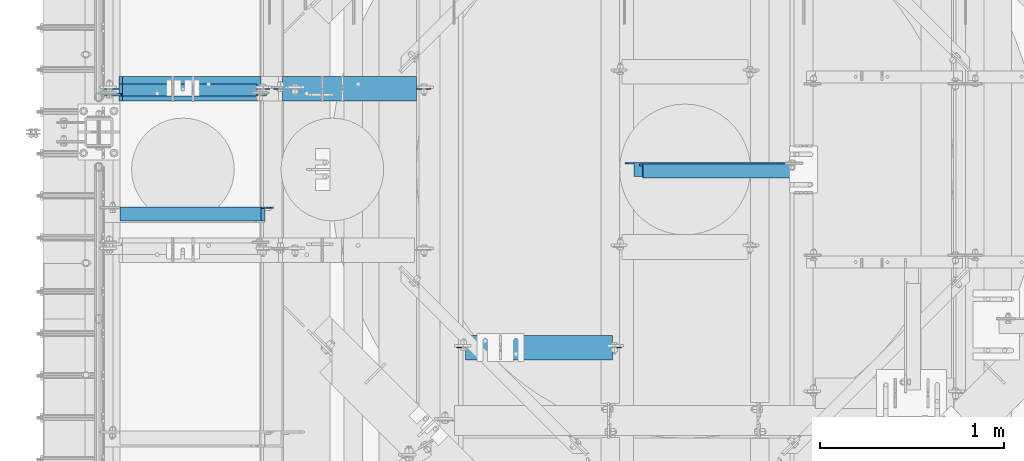
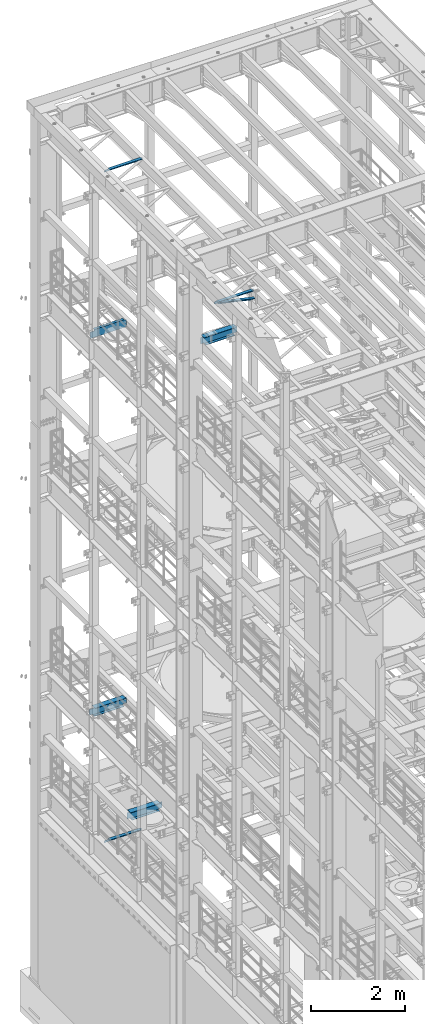
# One storey, part 1310 of 1876: 8 beams, 8 elements without a shape of their own.
"""IFC2X3 building model written with IfcOpenShell, lengths in millimetres."""

from ifc_helpers import new_model, si_unit, frame, origin_with_axes, place, context, subcontext, project, spatial, faceted_brep, material, type_object, element, aggregate, save


model = new_model("IFC2X3")

# Units and contexts
model_context = context("Model", 3, precision=1e-05, world=origin_with_axes())
body_context = subcontext(model_context, "Body", "Model", "MODEL_VIEW")
ifc_project = project(units=[si_unit("LENGTHUNIT", "METRE", prefix="MILLI"), si_unit("AREAUNIT", "SQUARE_METRE"), si_unit("VOLUMEUNIT", "CUBIC_METRE"), si_unit("MASSUNIT", "GRAM", prefix="KILO"), si_unit("TIMEUNIT", "SECOND"), si_unit("PLANEANGLEUNIT", "RADIAN"), si_unit("SOLIDANGLEUNIT", "STERADIAN"), si_unit("THERMODYNAMICTEMPERATUREUNIT", "DEGREE_CELSIUS"), si_unit("LUMINOUSINTENSITYUNIT", "LUMEN")], contexts=[model_context])

# Site, building, storey
site_placement = place(None, origin_with_axes())
site = spatial("IfcSite", under=ifc_project, at=site_placement, CompositionType="ELEMENT")
building_placement = place(site_placement, origin_with_axes())
building = spatial("IfcBuilding", under=site, at=building_placement, Name="Undefined", CompositionType="ELEMENT")
storey_placement = place(building_placement, origin_with_axes())
storey = spatial("IfcBuildingStorey", under=building, at=storey_placement, Name="Undefined", CompositionType="ELEMENT", Elevation=0.0)

# Assembly, beam
assembly_1_placement = place(storey_placement, origin_with_axes())
assembly_1 = element("IfcElementAssembly", 1, at=assembly_1_placement, inside=storey, AssemblyPlace="NOTDEFINED", PredefinedType="RIGID_FRAME")
ifc_material_1 = material(Name="STEEL/A36")
beam_type_1 = type_object("IfcBeamType", Name="L3X3X3/8", PredefinedType="NOTDEFINED")
beam_1_placement = place(assembly_1_placement, frame((2849.26107108996, 11471.2777255477, 17946.0015811523), z_axis=(0.0, -1.0, 0.0), x_axis=(0.976336452709797, -1.1799999937027e-07, -0.216257094935719)))
beam_1 = element("IfcBeam", 2, at=beam_1_placement, type_object=beam_type_1, material=ifc_material_1, ObjectType="L3X3X3/8", context=body_context, shape_type="Brep", body=[
    faceted_brep([(102.771194665975, 38.0999999998821, -38.1000000000022), (102.771194655534, 38.0999999999185, 38.0999999999967), (982.088984028022, 38.0999999990454, 38.0999999997002), (982.088984038462, 38.099999999009, -38.1000000003005), (102.771194655542, 28.5749999999207, 38.0999999999876), (982.08898402803, 28.5749999990512, 38.0999999996911), (102.771194664678, 28.5749999998843, -28.5750000000098), (982.088984037165, 28.5749999990148, -28.5750000003081), (102.771194664737, -38.100000000115, -28.5750000000698), (982.088984037224, -38.1000000009881, -28.5750000003663), (102.771194666042, -38.100000000115, -38.1000000000695), (982.088984038529, -38.1000000009881, -38.100000000366)], [[[0, 1, 2, 3]], [[1, 4, 5, 2]], [[4, 6, 7, 5]], [[6, 8, 9, 7]], [[8, 10, 11, 9]], [[10, 0, 3, 11]], [[5, 7, 9, 11, 3, 2]], [[10, 8, 6, 4, 1, 0]]]),
])
aggregate(assembly_1, [beam_1])

assembly_2_placement = place(storey_placement, origin_with_axes())
assembly_2 = element("IfcElementAssembly", 3, at=assembly_2_placement, inside=storey, Name="ANGLE", AssemblyPlace="NOTDEFINED", PredefinedType="RIGID_FRAME")
beam_2_placement = place(assembly_2_placement, frame((2857.5004675642, 11480.8027243222, 17945.1), z_axis=(0.0, -1.0, 0.0), x_axis=(1.0, 0.0, 0.0)))
beam_2 = element("IfcBeam", 4, at=beam_2_placement, type_object=beam_type_1, material=ifc_material_1, Name="ANGLE", ObjectType="L3X3X3/8", context=body_context, shape_type="Brep", body=[
    faceted_brep([(52.3865366794171, 28.5750001907327, 38.0999999999549), (52.3865366794516, 38.0999999999985, 38.0999999999549), (52.3865254019083, 38.0999999999985, -38.100000000044), (52.3865254018733, 28.5750001907327, -38.100000000044), (52.3865268115665, 28.5750000000007, -28.5750000000444), (15.8745234106468, 28.5750001907327, -38.1000000000149), (15.87452482034, 28.5750000000007, -28.5750000000135), (3.17452360138122, 15.8750003814675, -38.100000000004), (3.17452501107437, 15.8750003814675, -28.5750000000044), (3.17452360138122, 3.17500152587672, -38.100000000004), (3.17452501107437, 3.17500152587672, -28.5750000000044), (3.17452782573082, -38.0999999999985, -38.100000000004), (3.17452897824751, -38.0999999999985, -28.5750000000044), (971.549531402381, 15.8750003814675, -28.5750000008029), (958.849531593117, 28.5750000000007, -28.575000000792), (922.33752960189, 28.5750000000007, -28.5750000007611), (971.549528978267, -38.0999999999985, -28.5750000008029), (971.549531402381, 3.17500152587672, -28.5750000008029), (922.33753946974, 28.5750000108237, 38.0999999992382), (922.337539469706, 38.0999999999985, 38.0999999992382), (922.337528192162, 38.0999999999985, -38.1000000007607), (922.337528192197, 28.5750001907327, -38.1000000007607), (958.849530183424, 28.5750001907327, -38.1000000007916), (971.549529992689, 15.8750003814675, -38.1000000008025), (971.549529992689, 3.17500152587672, -38.1000000008025), (971.549527825751, -38.0999999999985, -38.1000000008025)], [[[0, 1, 2, 3, 4]], [[4, 3, 5, 6]], [[6, 5, 7, 8]], [[8, 7, 9, 10]], [[9, 11, 12, 10]], [[13, 14, 15, 4, 6, 8, 10, 12, 16, 17]], [[0, 4, 15, 18]], [[1, 0, 18, 19]], [[2, 1, 19, 20]], [[18, 15, 21, 20, 19]], [[14, 22, 21, 15]], [[13, 23, 22, 14]], [[17, 24, 23, 13]], [[11, 9, 7, 5, 3, 2, 20, 21, 22, 23, 24, 25]], [[12, 11, 25, 16]], [[24, 17, 16, 25]]]),
])
aggregate(assembly_2, [beam_2])

assembly_3_placement = place(storey_placement, origin_with_axes())
assembly_3 = element("IfcElementAssembly", 5, at=assembly_3_placement, inside=storey, Name="ANGLE", AssemblyPlace="NOTDEFINED", PredefinedType="RIGID_FRAME")
beam_3_placement = place(assembly_3_placement, frame((4.51516825708356e-09, 11239.5, 22517.1), z_axis=(0.0, -1.0, 0.0), x_axis=(1.0, 0.0, 0.0)))
beam_3 = element("IfcBeam", 6, at=beam_3_placement, type_object=beam_type_1, material=ifc_material_1, Name="ANGLE", ObjectType="L3X3X3/8", context=body_context, shape_type="Brep", body=[
    faceted_brep([(115.886999817316, 28.5750000000007, 38.0999999999999), (115.886999817316, 38.0999999999985, 38.0999999999999), (115.886998826692, 38.0999999999985, -38.0999999999999), (115.88699882669, 12.699999237062, -38.0999999999999), (115.886998950515, 12.699999237062, -28.5749999999998), (115.88699895052, 28.5750000000007, -28.5749999999998), (38.8937432114558, 12.699999237062, -38.0999999999999), (38.8937433352807, 12.699999237062, -28.5749999999998), (7.14374321145577, -19.050000762938, -38.0999999999999), (7.14374333528067, -19.050000762938, -28.5749999999998), (7.1437499954859, -38.0999999999985, -38.0999999999999), (7.1437499954859, -38.0999999999985, -28.5749999999998), (949.325002419604, 15.8750003814712, -28.5749999999998), (936.625002610339, 28.5750000000007, -28.5749999999998), (900.113000619098, 28.5750000000007, -28.5749999999998), (949.324999995485, -38.0999999999985, -28.5749999999998), (949.325002419604, 3.17500152588036, -28.5749999999998), (900.11300241932, 28.5750000000007, 38.0999999999999), (900.1130024193, 38.0999999999985, 38.0999999999999), (900.113000361957, 38.0999999999985, -38.0999999999999), (900.113000361924, 28.5750001907363, -38.0999999999999), (936.625002353164, 28.5750001907363, -38.0999999999999), (949.325002162429, 15.8750003814712, -38.0999999999999), (949.325002162429, 3.17500152588036, -38.0999999999999), (949.324999995485, -38.0999999999985, -38.0999999999999)], [[[0, 1, 2, 3, 4, 5]], [[4, 3, 6, 7]], [[7, 6, 8, 9]], [[8, 10, 11, 9]], [[12, 13, 14, 5, 4, 7, 9, 11, 15, 16]], [[0, 5, 14, 17]], [[1, 0, 17, 18]], [[2, 1, 18, 19]], [[17, 14, 20, 19, 18]], [[13, 21, 20, 14]], [[12, 22, 21, 13]], [[16, 23, 22, 12]], [[10, 8, 6, 3, 2, 19, 20, 21, 22, 23, 24]], [[11, 10, 24, 15]], [[23, 16, 15, 24]]]),
])
aggregate(assembly_3, [beam_3])

assembly_4_placement = place(storey_placement, origin_with_axes())
assembly_4 = element("IfcElementAssembly", 7, at=assembly_4_placement, inside=storey, Name="ANGLE", AssemblyPlace="NOTDEFINED", PredefinedType="RIGID_FRAME")
beam_4_placement = place(assembly_4_placement, frame((0.0, 11239.5, 5092.7), z_axis=(0.0, -1.0, 0.0), x_axis=(1.0, 0.0, 0.0)))
beam_4 = element("IfcBeam", 8, at=beam_4_placement, type_object=beam_type_1, material=ifc_material_1, Name="ANGLE", ObjectType="L3X3X3/8", context=body_context, shape_type="Brep", body=[
    faceted_brep([(115.886999817316, 28.5750000000007, 38.0999999999999), (115.886999817316, 38.0999999999985, 38.0999999999999), (115.886998826692, 38.0999999999985, -38.0999999999999), (115.88699882669, 12.699999237062, -38.0999999999999), (115.886998950515, 12.699999237062, -28.5749999999998), (115.88699895052, 28.5750000000007, -28.5749999999998), (38.8937432114558, 12.699999237062, -38.0999999999999), (38.8937433352807, 12.699999237062, -28.5749999999998), (7.14374321145577, -19.050000762938, -38.0999999999999), (7.14374333528067, -19.050000762938, -28.5749999999998), (7.1437499954859, -38.0999999999985, -38.0999999999999), (7.1437499954859, -38.0999999999985, -28.5749999999998), (930.275002424124, 15.8750003814703, -28.5750000000007), (917.575002614859, 28.5749999999998, -28.5750000000007), (881.063000623622, 28.5749999999998, -28.5750000000007), (930.274999999999, -38.1000000000004, -28.5750000000007), (930.275002424124, 3.17500152587945, -28.5750000000007), (881.063002423843, 28.5749999999998, 38.1000000000004), (881.063002423821, 38.1000000000004, 38.1000000000004), (881.063000366478, 38.1000000000004, -38.1000000000004), (881.063000366447, 28.5750001907354, -38.1000000000004), (917.575002357685, 28.5750001907354, -38.1000000000004), (930.27500216695, 15.8750003814703, -38.1000000000004), (930.27500216695, 3.17500152587945, -38.1000000000004), (930.274999999999, -38.1000000000004, -38.1000000000004)], [[[0, 1, 2, 3, 4, 5]], [[4, 3, 6, 7]], [[7, 6, 8, 9]], [[8, 10, 11, 9]], [[12, 13, 14, 5, 4, 7, 9, 11, 15, 16]], [[0, 5, 14, 17]], [[1, 0, 17, 18]], [[2, 1, 18, 19]], [[17, 14, 20, 19, 18]], [[13, 21, 20, 14]], [[12, 22, 21, 13]], [[16, 23, 22, 12]], [[10, 8, 6, 3, 2, 19, 20, 21, 22, 23, 24]], [[11, 10, 24, 15]], [[23, 16, 15, 24]]]),
])
aggregate(assembly_4, [beam_4])

assembly_5_placement = place(storey_placement, origin_with_axes())
assembly_5 = element("IfcElementAssembly", 9, at=assembly_5_placement, inside=storey, Name="BEAM", AssemblyPlace="NOTDEFINED", PredefinedType="RIGID_FRAME")
ifc_material_2 = material(Name="STEEL/A992")
beam_type_2 = type_object("IfcBeamType", Name="W8X18", PredefinedType="NOTDEFINED")
beam_5_placement = place(assembly_5_placement, frame((1930.4097390092, 10512.4226196289, 17880.0125), z_axis=(0.0, 0.0, 1.0), x_axis=(1.0, 0.0, 0.0)))
beam_5 = element("IfcBeam", 10, at=beam_5_placement, type_object=beam_type_2, material=ifc_material_2, Name="BEAM", ObjectType="W8X18", context=body_context, shape_type="Brep", body=[
    faceted_brep([(819.140260990796, -3.17499999999927, -95.25), (819.140260990796, -66.6749999999993, -95.25), (819.140260990796, -66.6749999999993, -103.1875), (819.140260990796, 66.6749999999993, -103.1875), (819.140260990796, 66.6749999999993, -95.25), (819.140260990796, 3.17499999999927, -95.25), (819.140260990796, 3.17499999999927, -90.48749980926), (819.140260990796, -3.17499999999927, -90.48749980926), (820.106990913384, 3.17499999999927, -85.6274202912136), (820.106990913384, -3.17499999999927, -85.6274202912136), (822.860004813862, 3.17499999999927, -81.50724382306), (822.860004813862, -3.17499999999927, -81.50724382306), (826.980181282016, 3.17499999999927, -78.7542299225825), (826.980181282016, -3.17499999999927, -78.7542299225825), (831.840260800061, 3.17499999999927, -77.7874999999949), (831.840260800061, -3.17499999999927, -77.7874999999949), (911.215260990796, -3.17499999999927, -77.7874999999949), (911.215260990796, 3.17499999999927, -77.7874999999949), (63.4902609907954, 66.6749999999993, 103.1875), (63.4902609907954, -66.6749999999993, 103.1875), (863.590260990796, -66.6749999999993, 103.1875), (863.590260990796, 66.6749999999993, 103.1875), (63.4902609907954, 66.6749999999993, 96.8374998092695), (63.4902609907954, -66.6749999999993, 96.8374998092695), (63.1744876455189, -66.6749999999993, 95.25), (863.906034336073, -66.6749999999993, 95.25), (863.590260990796, -66.6749999999993, 96.8374998092695), (863.590260990796, 66.6749999999993, 96.8374998092695), (63.1744876455189, 66.6749999999993, 95.25), (863.906034336073, 66.6749999999993, 95.25), (63.1744876455189, 3.17499999999927, 95.25), (863.906034336073, 3.17499999999927, 95.25), (107.940260990795, -3.17499999999927, -90.48749980926), (107.940260990795, 3.17499999999927, -90.48749980926), (107.940260990795, 3.17499999999927, -95.25), (107.940260990795, 66.6749999999993, -95.25), (107.940260990795, 66.6749999999993, -103.1875), (107.940260990795, -66.6749999999993, -103.1875), (107.940260990795, -66.6749999999993, -95.25), (107.940260990795, -3.17499999999927, -95.25), (106.973531068208, -3.17499999999927, -85.6274202912136), (106.973531068208, 3.17499999999927, -85.6274202912136), (104.220517167729, -3.17499999999927, -81.50724382306), (104.220517167729, 3.17499999999927, -81.50724382306), (100.100340699576, -3.17499999999927, -78.7542299225825), (100.100340699576, 3.17499999999927, -78.7542299225825), (95.2402611815303, -3.17499999999927, -77.7874999999949), (95.2402611815303, 3.17499999999927, -77.7874999999949), (15.8652609907954, -3.17499999999927, -77.7874999999949), (15.8652609907954, 3.17499999999927, -77.7874999999949), (15.8652609907954, -3.17499999999927, 84.1375000000044), (15.8652609907954, 3.17499999999927, 84.1375000000044), (50.7902611815302, -3.17499999999927, 84.1375000000044), (50.7902611815302, 3.17499999999927, 84.1375000000044), (55.6503406995757, -3.17499999999927, 85.1042299225919), (55.6503406995757, 3.17499999999927, 85.1042299225919), (59.7705171677294, -3.17499999999927, 87.8572438230694), (59.7705171677294, 3.17499999999927, 87.8572438230694), (62.5235310682076, -3.17499999999927, 91.9774202912231), (62.5235310682076, 3.17499999999927, 91.9774202912231), (63.1744876455189, -3.17499999999927, 95.25), (863.906034336073, -3.17499999999927, 95.25), (864.556990913384, -3.17499999999927, 91.9774202912231), (864.556990913384, 3.17499999999927, 91.9774202912231), (867.310004813862, -3.17499999999927, 87.8572438230694), (867.310004813862, 3.17499999999927, 87.8572438230694), (871.430181282016, -3.17499999999927, 85.1042299225919), (871.430181282016, 3.17499999999927, 85.1042299225919), (876.290260800061, -3.17499999999927, 84.1375000000044), (876.290260800061, 3.17499999999927, 84.1375000000044), (911.215260990796, -3.17499999999927, 84.1375000000044), (911.215260990796, 3.17499999999927, 84.1375000000044)], [[[0, 1, 2, 3, 4, 5, 6, 7]], [[7, 6, 8, 9]], [[9, 8, 10, 11]], [[11, 10, 12, 13]], [[13, 12, 14, 15]], [[16, 15, 14, 17]], [[18, 19, 20, 21]], [[19, 18, 22, 23]], [[20, 19, 23, 24, 25, 26]], [[20, 26, 27, 21]], [[28, 22, 18, 21, 27, 29]], [[30, 28, 29, 31]], [[32, 33, 34, 35, 36, 37, 38, 39]], [[40, 41, 33, 32]], [[42, 43, 41, 40]], [[44, 45, 43, 42]], [[46, 47, 45, 44]], [[48, 49, 47, 46]], [[50, 51, 49, 48]], [[52, 53, 51, 50]], [[54, 55, 53, 52]], [[56, 57, 55, 54]], [[58, 59, 57, 56]], [[23, 22, 28, 30, 59, 58, 60, 24]], [[24, 60, 61, 25]], [[62, 63, 31, 29, 27, 26, 25, 61]], [[64, 65, 63, 62]], [[66, 67, 65, 64]], [[68, 69, 67, 66]], [[70, 71, 69, 68]], [[71, 70, 16, 17]], [[12, 10, 8, 6, 5, 34, 33, 41, 43, 45, 47, 49, 51, 53, 55, 57, 59, 30, 31, 63, 65, 67, 69, 71, 17, 14]], [[35, 34, 5, 4]], [[36, 35, 4, 3]], [[37, 36, 3, 2]], [[38, 37, 2, 1]], [[39, 38, 1, 0]], [[70, 68, 66, 64, 62, 61, 60, 58, 56, 54, 52, 50, 48, 46, 44, 42, 40, 32, 39, 0, 7, 9, 11, 13, 15, 16]]]),
])
aggregate(assembly_5, [beam_5])

assembly_6_placement = place(storey_placement, origin_with_axes())
assembly_6 = element("IfcElementAssembly", 11, at=assembly_6_placement, inside=storey, Name="BEAM", AssemblyPlace="NOTDEFINED", PredefinedType="RIGID_FRAME")
beam_6_placement = place(assembly_6_placement, frame((0.0, 11918.95, 8050.2125), z_axis=(0.0, 0.0, 1.0), x_axis=(1.0, 0.0, 0.0)))
beam_6 = element("IfcBeam", 12, at=beam_6_placement, type_object=beam_type_2, material=ifc_material_2, Name="BEAM", ObjectType="W8X18", context=body_context, shape_type="Brep", body=[
    faceted_brep([(19.8437500000002, -3.17500000000018, -77.7874999999985), (19.8437500000002, 3.17500000000018, -77.7874999999985), (96.043750190735, 3.17499999999927, -77.7875000000004), (96.043750190735, -3.17499999999927, -77.7875000000004), (100.903829708781, 3.17499999999927, -78.7542299225879), (100.903829708781, -3.17499999999927, -78.7542299225879), (105.024006176934, 3.17499999999927, -81.5072438230654), (105.024006176934, -3.17499999999927, -81.5072438230654), (107.777020077412, 3.17499999999927, -85.6274202912191), (107.777020077412, -3.17499999999927, -85.6274202912191), (108.74375, -3.17499999999927, -90.4874998092655), (108.74375, 3.17499999999927, -90.4874998092655), (108.74375, 3.17499999999927, -95.25), (108.74375, 66.6749999999993, -95.25), (108.74375, 66.6750000000002, -103.1875), (108.74375, -66.6750000000002, -103.1875), (108.74375, -66.6749999999993, -95.25), (108.74375, -3.17499999999927, -95.25), (127.79375, 66.6749999999993, 103.1875), (127.79375, -66.6749999999993, 103.1875), (882.649999999999, -66.6749999999993, 103.1875), (882.649999999999, 66.6749999999993, 103.1875), (127.79375, -66.6749999999993, 95.25), (882.965773345275, -66.6749999999993, 95.25), (882.649999999999, -66.6749999999993, 96.837499809264), (882.649999999999, 66.6749999999993, 96.837499809264), (127.79375, 66.6749999999993, 95.25), (882.965773345275, 66.6749999999993, 95.25), (127.79375, 3.17499999999927, 95.25), (882.965773345275, 3.17499999999927, 95.25), (115.093750190735, -3.17499999999927, 71.4375), (115.093750190735, 3.17499999999927, 71.4375), (19.8437499999999, 3.17499999999927, 71.4375), (19.8437499999999, -3.17499999999927, 71.4375), (119.953829708781, -3.17499999999927, 72.4042299225875), (119.953829708781, 3.17499999999927, 72.4042299225875), (124.074006176934, -3.17499999999927, 75.1572438230651), (124.074006176934, 3.17499999999927, 75.1572438230651), (126.827020077412, -3.17499999999927, 79.2774202912187), (126.827020077412, 3.17499999999927, 79.2774202912187), (127.79375, -3.17499999999927, 84.1374998092651), (127.79375, 3.17499999999927, 84.1374998092651), (127.79375, -3.17499999999927, 95.25), (882.965773345275, -3.17499999999927, 95.25), (883.616729922587, -3.17499999999927, 91.9774202912186), (883.616729922587, 3.17499999999927, 91.9774202912186), (886.369743823065, -3.17499999999927, 87.8572438230649), (886.369743823065, 3.17499999999927, 87.8572438230649), (890.489920291219, -3.17499999999927, 85.1042299225865), (890.489920291219, 3.17499999999927, 85.1042299225865), (895.349999809265, -3.17499999999927, 84.1374999999989), (895.349999809265, 3.17499999999927, 84.1374999999989), (930.275, -3.17499999999927, 84.1374999999989), (930.275, 3.17499999999927, 84.1374999999989), (930.275, -3.17499999999927, -77.7875000000013), (930.275, 3.17499999999927, -77.7875000000013), (854.074999809265, -3.17499999999927, -77.7875000000013), (854.074999809265, 3.17499999999927, -77.7875000000013), (849.214920291219, -3.17499999999927, -78.7542299225888), (849.214920291219, 3.17499999999927, -78.7542299225888), (845.094743823065, -3.17499999999927, -81.5072438230673), (845.094743823065, 3.17499999999927, -81.5072438230673), (842.341729922587, -3.17499999999927, -85.6274202912209), (842.341729922587, 3.17499999999927, -85.6274202912209), (841.374999999999, -3.17499999999927, -90.4874998092664), (841.374999999999, 3.17499999999927, -90.4874998092664), (841.374999999999, -3.17499999999927, -95.25), (841.374999999999, -66.6749999999993, -95.25), (841.374999999999, -66.6749999999993, -103.1875), (841.374999999999, 66.6749999999993, -103.1875), (841.374999999999, 66.6749999999993, -95.25), (841.374999999999, 3.17499999999927, -95.25)], [[[0, 1, 2, 3]], [[3, 2, 4, 5]], [[5, 4, 6, 7]], [[7, 6, 8, 9]], [[10, 11, 12, 13, 14, 15, 16, 17]], [[9, 8, 11, 10]], [[18, 19, 20, 21]], [[20, 19, 22, 23, 24]], [[20, 24, 25, 21]], [[26, 18, 21, 25, 27]], [[28, 26, 27, 29]], [[30, 31, 32, 33]], [[34, 35, 31, 30]], [[36, 37, 35, 34]], [[38, 39, 37, 36]], [[40, 41, 39, 38]], [[19, 18, 26, 28, 41, 40, 42, 22]], [[22, 42, 43, 23]], [[44, 45, 29, 27, 25, 24, 23, 43]], [[46, 47, 45, 44]], [[48, 49, 47, 46]], [[50, 51, 49, 48]], [[52, 53, 51, 50]], [[53, 52, 54, 55]], [[54, 56, 57, 55]], [[58, 59, 57, 56]], [[60, 61, 59, 58]], [[62, 63, 61, 60]], [[64, 65, 63, 62]], [[66, 67, 68, 69, 70, 71, 65, 64]], [[67, 66, 17, 16]], [[68, 67, 16, 15]], [[69, 68, 15, 14]], [[70, 69, 14, 13]], [[71, 70, 13, 12]], [[6, 4, 2, 1, 32, 31, 35, 37, 39, 41, 28, 29, 45, 47, 49, 51, 53, 55, 57, 59, 61, 63, 65, 71, 12, 11, 8]], [[33, 32, 1, 0]], [[66, 64, 62, 60, 58, 56, 54, 52, 50, 48, 46, 44, 43, 42, 40, 38, 36, 34, 30, 33, 0, 3, 5, 7, 9, 10, 17]]]),
])
aggregate(assembly_6, [beam_6])

assembly_7_placement = place(storey_placement, origin_with_axes())
assembly_7 = element("IfcElementAssembly", 13, at=assembly_7_placement, inside=storey, Name="BEAM", AssemblyPlace="NOTDEFINED", PredefinedType="RIGID_FRAME")
beam_7_placement = place(assembly_7_placement, frame((730.25, 11918.95, 5027.6125), z_axis=(0.0, 0.0, -1.0), x_axis=(1.0, 0.0, 0.0)))
beam_7 = element("IfcBeam", 14, at=beam_7_placement, type_object=beam_type_2, material=ifc_material_2, Name="BEAM", ObjectType="W8X18", context=body_context, shape_type="Brep", body=[
    faceted_brep([(996.949999999998, -3.17499999999927, -95.25), (996.949999999998, -66.6749999999993, -95.25), (996.949999999998, -66.6749999999993, -103.1875), (996.949999999998, 66.6749999999993, -103.1875), (996.949999999998, 66.6749999999993, -95.25), (996.949999999998, 3.17499999999927, -95.25), (996.949999999998, 3.17499999999927, -90.4874998092655), (996.949999999998, -3.17499999999927, -90.4874998092655), (997.916729922585, 3.17499999999927, -85.62742029122), (997.916729922585, -3.17499999999927, -85.62742029122), (1000.66974382306, 3.17499999999927, -81.5072438230663), (1000.66974382306, -3.17499999999927, -81.5072438230663), (1004.78992029122, 3.17499999999927, -78.7542299225879), (1004.78992029122, -3.17499999999927, -78.7542299225879), (1009.64999980926, 3.17499999999927, -77.7875000000004), (1009.64999980926, -3.17499999999927, -77.7875000000004), (1076.325, -3.17500000000018, -77.7874999999985), (1076.325, 3.17500000000018, -77.7874999999985), (987.424999999997, 66.6749999999993, 95.25), (987.424999999997, 3.17499999999927, 95.25), (307.975, 3.17499999999927, 95.25), (307.975, 66.6749999999993, 95.25), (269.875, -66.6749999999993, -96.837499809264), (269.875, 66.6749999999993, -96.837499809264), (269.875, 66.6749999999993, -103.1875), (269.875, -66.6749999999993, -103.1875), (269.559226654725, -66.6749999999993, -95.25), (269.559226654725, -3.17499999999927, -95.25), (268.908270077412, -3.17499999999927, -91.9774202912186), (268.908270077412, 3.17499999999927, -91.9774202912186), (269.559226654725, 3.17499999999927, -95.25), (269.559226654725, 66.6749999999993, -95.25), (266.155256176934, -3.17499999999927, -87.8572438230649), (266.155256176934, 3.17499999999927, -87.8572438230649), (262.03507970878, -3.17499999999927, -85.1042299225865), (262.03507970878, 3.17499999999927, -85.1042299225865), (257.175000190735, -3.17499999999927, -84.1374999999989), (257.175000190735, 3.17499999999927, -84.1374999999989), (219.075, -3.17499999999927, -84.1374999999989), (219.075, 3.17499999999927, -84.1374999999989), (219.075, -3.17499999999927, 77.7875000000013), (219.075, 3.17499999999927, 77.7875000000013), (295.275000190735, -3.17499999999927, 77.7875000000013), (295.275000190735, 3.17499999999927, 77.7875000000013), (300.13507970878, -3.17499999999927, 78.7542299225888), (300.13507970878, 3.17499999999927, 78.7542299225888), (304.255256176934, -3.17499999999927, 81.5072438230673), (304.255256176934, 3.17499999999927, 81.5072438230673), (307.008270077412, -3.17499999999927, 85.6274202912209), (307.008270077412, 3.17499999999927, 85.6274202912209), (307.975, -3.17499999999927, 90.4874998092664), (307.975, 3.17499999999927, 90.4874998092664), (987.424999999997, -66.6749999999993, 103.1875), (987.424999999997, 66.6749999999993, 103.1875), (307.975, 66.6749999999993, 103.1875), (307.975, -66.6749999999993, 103.1875), (987.424999999997, -66.6749999999993, 95.25), (307.975, -66.6749999999993, 95.25), (987.424999999997, -3.17499999999927, 95.25), (307.975, -3.17499999999927, 95.25), (987.424999999997, -3.17499999999927, 90.4874998092664), (987.424999999997, 3.17499999999927, 90.4874998092664), (988.391729922585, -3.17499999999927, 85.6274202912209), (988.391729922585, 3.17499999999927, 85.6274202912209), (991.144743823063, -3.17499999999927, 81.5072438230673), (991.144743823063, 3.17499999999927, 81.5072438230673), (995.264920291217, -3.17499999999927, 78.7542299225888), (995.264920291217, 3.17499999999927, 78.7542299225888), (1000.125, -3.17500000000018, 77.7875000000013), (1000.125, 3.17500000000018, 77.7875000000013), (1076.325, -3.17500000000018, 77.7874999999985), (1076.325, 3.17500000000018, 77.7874999999985)], [[[0, 1, 2, 3, 4, 5, 6, 7]], [[7, 6, 8, 9]], [[9, 8, 10, 11]], [[11, 10, 12, 13]], [[13, 12, 14, 15]], [[16, 15, 14, 17]], [[18, 19, 20, 21]], [[22, 23, 24, 25]], [[26, 27, 28, 29, 30, 31, 23, 22]], [[32, 33, 29, 28]], [[34, 35, 33, 32]], [[36, 37, 35, 34]], [[38, 39, 37, 36]], [[40, 41, 39, 38]], [[42, 43, 41, 40]], [[44, 45, 43, 42]], [[46, 47, 45, 44]], [[48, 49, 47, 46]], [[50, 51, 49, 48]], [[52, 53, 54, 55]], [[56, 52, 55, 57]], [[58, 56, 57, 59]], [[55, 54, 21, 20, 51, 50, 59, 57]], [[53, 18, 21, 54]], [[52, 56, 58, 60, 61, 19, 18, 53]], [[62, 63, 61, 60]], [[64, 65, 63, 62]], [[66, 67, 65, 64]], [[68, 69, 67, 66]], [[70, 71, 69, 68]], [[71, 70, 16, 17]], [[12, 10, 8, 6, 5, 30, 29, 33, 35, 37, 39, 41, 43, 45, 47, 49, 51, 20, 19, 61, 63, 65, 67, 69, 71, 17, 14]], [[31, 30, 5, 4]], [[24, 23, 31, 4, 3]], [[25, 24, 3, 2]], [[26, 22, 25, 2, 1]], [[27, 26, 1, 0]], [[70, 68, 66, 64, 62, 60, 58, 59, 50, 48, 46, 44, 42, 40, 38, 36, 34, 32, 28, 27, 0, 7, 9, 11, 13, 15, 16]]]),
])
aggregate(assembly_7, [beam_7])

assembly_8_placement = place(storey_placement, origin_with_axes())
assembly_8 = element("IfcElementAssembly", 15, at=assembly_8_placement, inside=storey, Name="BEAM", AssemblyPlace="NOTDEFINED", PredefinedType="RIGID_FRAME")
beam_type_3 = type_object("IfcBeamType", Name="C8X18.75", PredefinedType="NOTDEFINED")
beam_8_placement = place(assembly_8_placement, frame((-3.97903932025656e-13, 11912.597277832, 17881.6), z_axis=(0.0, 0.0, -1.0), x_axis=(1.0, 0.0, 0.0)))
beam_8 = element("IfcBeam", 16, at=beam_8_placement, type_object=beam_type_3, material=ifc_material_1, Name="BEAM", ObjectType="C8X18.75", context=body_context, shape_type="Brep", body=[
    faceted_brep([(828.674999999968, -31.75, 101.600000012928), (828.674999999968, -31.75, 97.3645499999984), (828.674999999968, 19.0499999999993, 88.9012699999985), (828.674999999968, 19.0495000839837, 101.599999961727), (911.225, 19.0495000839837, 101.599999999999), (911.224999996825, 19.0499999999993, 88.9012699999985), (911.225, 19.0499999999993, -57.1500076293996), (911.224999996825, 19.0499999999993, -82.5499999999993), (911.224999996825, 31.75, -82.5499999999993), (911.224999996825, 31.75, 101.599999999999), (860.425, -19.0576219043705, -95.249999809268), (860.425, 31.75, -95.249999809268), (861.391729922588, 31.75, -90.3899202912216), (861.391729922588, 10.11452406229, -90.3899202912216), (860.425, -31.75, -97.3645499999984), (860.425, -31.75, -101.599999999999), (860.425, 31.75, -101.599999999999), (127.79375, -31.75, -97.3645499999984), (127.79375, -31.75, -101.599999999999), (127.79375, 31.75, -101.599999999999), (124.074006176934, 31.75, -67.2197438230687), (119.953829708781, 31.75, -64.4667299225912), (115.093750190735, 31.75, -63.5000000000036), (19.8437500000003, 31.75, -63.5000000000036), (19.8437500000003, 31.75, 101.599999999999), (873.124999809265, 31.75, -82.5500000000029), (868.26492029122, 31.75, -83.5167299225905), (864.144743823066, 31.75, -86.269743823068), (127.79375, 31.75, -76.1999998092688), (126.827020077413, 31.75, -71.3399202912224), (873.124999809265, 19.0499999999993, -82.5500000000029), (868.26492029122, 19.0499999999993, -83.5167299225905), (864.144743823066, 19.0499999999993, -86.269743823068), (862.386414246515, 19.0499999999993, -88.9012699999985), (127.79375, 19.0499999999993, -88.9000227205615), (127.79375, 19.0499999999993, -76.1999998092688), (126.827020077413, 19.0499999999993, -71.3399202912224), (124.074006176934, 19.0499999999993, -67.2197438230687), (119.953829708781, 19.0499999999993, -64.4667299225912), (115.093750190735, 19.0499999999993, -63.5000000000036), (19.8437500000003, 19.0499999999993, -63.5000000000036), (19.8437500000003, 19.0499999999993, 88.9012699999985), (19.8437500000003, 19.0495000839819, 101.599999999999), (96.0437500000353, 19.0499999999993, 88.9012699999985), (96.0437500000352, 19.0495000839819, 101.599999999999), (108.743751527648, -31.75, 101.60000012568), (108.743751527648, 19.0499999999993, 101.60000012568), (108.743749999992, 19.0499999999993, 88.9012699999985), (108.743751018139, -31.75, 97.3645499999984)], [[[0, 1, 2, 3]], [[4, 3, 2, 5]], [[6, 7, 8, 9, 4, 5]], [[10, 11, 12, 13]], [[14, 15, 16, 11, 10]], [[15, 14, 17, 18]], [[16, 15, 18, 19]], [[20, 21, 22, 23, 24, 9, 8, 25, 26, 27, 12, 11, 16, 19, 28, 29]], [[7, 30, 25, 8]], [[31, 26, 25, 30]], [[32, 27, 26, 31]], [[33, 13, 12, 27, 32]], [[14, 10, 13, 33, 34, 17]], [[35, 28, 19, 18, 17, 34]], [[36, 29, 28, 35]], [[37, 20, 29, 36]], [[38, 21, 20, 37]], [[39, 22, 21, 38]], [[40, 23, 22, 39]], [[41, 42, 24, 23, 40]], [[42, 41, 43, 44]], [[45, 46, 47, 48]], [[44, 43, 47, 46]], [[41, 40, 39, 38, 37, 36, 35, 34, 33, 32, 31, 30, 7, 6, 5, 2, 47, 43]], [[48, 47, 2, 1]], [[45, 48, 1, 0]], [[9, 24, 42, 44, 46, 45, 0, 3, 4]]]),
])
aggregate(assembly_8, [beam_8])

save(model, "model.ifc")
